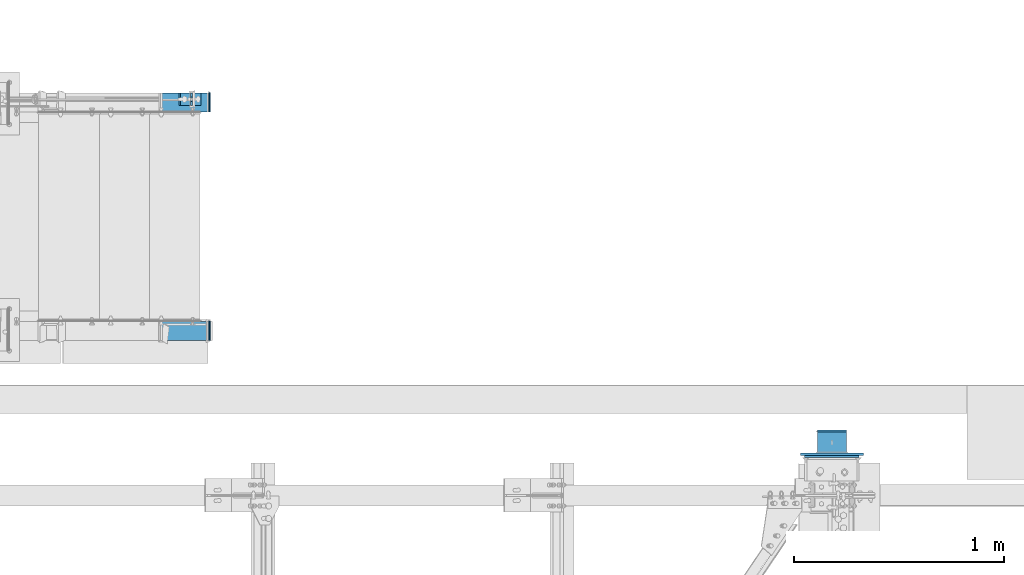
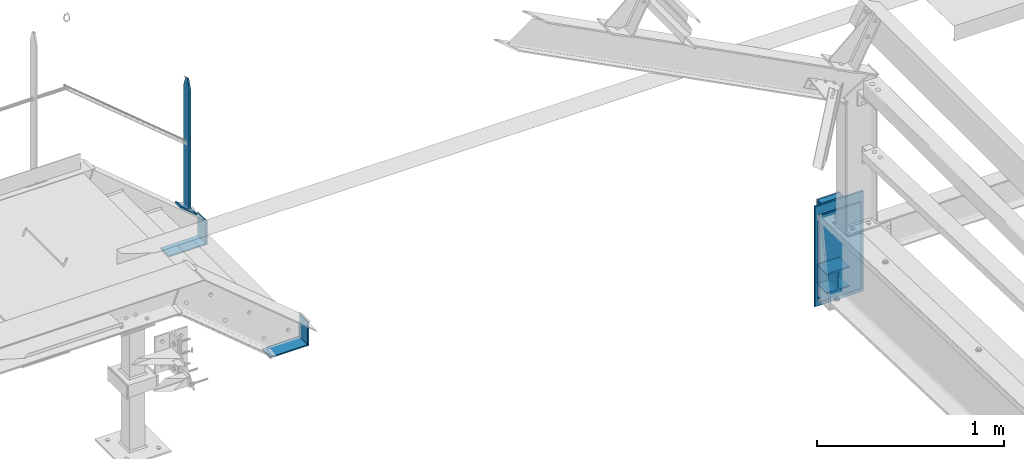
# One storey, part 99 of 496: 11 beams, 1 member, 5 elements without a shape of their own.
"""IFC2X3 building model written with IfcOpenShell, lengths in millimetres."""

from ifc_helpers import new_model, si_unit, frame, origin_with_axes, origin_2d_with_axis, place, context, subcontext, project, spatial, rectangle, i_section, extrude, clip, halfspace, material, type_object, element, aggregate, save


model = new_model("IFC2X3")

# Units and contexts
model_context = context("Model", 3, precision=1e-05, world=origin_with_axes())
body_context = subcontext(model_context, "Body", "Model", "MODEL_VIEW")
ifc_project = project(units=[si_unit("LENGTHUNIT", "METRE", prefix="MILLI"), si_unit("AREAUNIT", "SQUARE_METRE"), si_unit("VOLUMEUNIT", "CUBIC_METRE"), si_unit("MASSUNIT", "GRAM", prefix="KILO"), si_unit("TIMEUNIT", "SECOND"), si_unit("PLANEANGLEUNIT", "RADIAN"), si_unit("SOLIDANGLEUNIT", "STERADIAN"), si_unit("THERMODYNAMICTEMPERATUREUNIT", "DEGREE_CELSIUS"), si_unit("LUMINOUSINTENSITYUNIT", "LUMEN")], contexts=[model_context])

# Site, building, storey
site_placement = place(None, origin_with_axes())
site = spatial("IfcSite", under=ifc_project, at=site_placement, CompositionType="ELEMENT")
building_placement = place(site_placement, origin_with_axes())
building = spatial("IfcBuilding", under=site, at=building_placement, Name="Undefined", CompositionType="ELEMENT")
storey_placement = place(building_placement, origin_with_axes())
storey = spatial("IfcBuildingStorey", under=building, at=storey_placement, Name="Undefined", CompositionType="ELEMENT", Elevation=0.0)

# Assembly, beam
assembly_1_placement = place(storey_placement, origin_with_axes())
assembly_1 = element("IfcElementAssembly", 1, at=assembly_1_placement, inside=storey, Name="MAIN COURANTE", AssemblyPlace="NOTDEFINED", PredefinedType="NOTDEFINED")
ifc_material_1 = material(Name="Undefined/S235-E24")
beam_type_1 = type_object("IfcBeamType", PredefinedType="NOTDEFINED")
beam_1_placement = place(assembly_1_placement, frame((25825.0061849193, 17089.9938659712, 8458.13573617826), z_axis=(0.0, -1.0, 0.0), x_axis=(0.0, 0.0, -1.0)))
beam_1 = element("IfcBeam", 2, at=beam_1_placement, type_object=beam_type_1, material=ifc_material_1, Name="MONTANT", context=body_context, shape_type="Clipping", body=[
    clip(clip(clip(clip(extrude(rectangle(XDim=10.0, YDim=60.0, at=origin_2d_with_axis()), frame((860.207207578186, 0.0, 0.0), z_axis=(-1.0, 0.0, 0.0), x_axis=(0.0, -1.0, 0.0)), (0.0, 0.0, 1.0), 868.62), halfspace(frame((-120.0, 5.0, -30.0), z_axis=(-0.316227766016838, 0.0, 0.948683298050514), x_axis=(0.948683298050514, 0.0, 0.316227766016838)), False)), halfspace(frame((60.0, 5.0, -30.0), z_axis=(-0.316227766016838, 0.0, -0.948683298050514), x_axis=(-0.948683298050514, 0.0, 0.316227766016838)), False)), halfspace(frame((858.302366962016, 7.81419051646299, 0.0), z_axis=(0.768221279597369, -0.640184399664488, 0.0), x_axis=(0.0, 0.0, -1.0)), False)), halfspace(frame((5.77492361636723, 6.92990936078422, 0.0), z_axis=(0.768221279597369, -0.640184399664488, 0.0), x_axis=(0.0, 0.0, -1.0)), True)),
])

assembly_2_placement = place(storey_placement, origin_with_axes())
assembly_2 = element("IfcElementAssembly", 3, at=assembly_2_placement, inside=storey, AssemblyPlace="NOTDEFINED", PredefinedType="NOTDEFINED")
beam_type_2 = type_object("IfcBeamType", PredefinedType="NOTDEFINED")
beam_2_placement = place(assembly_2_placement, frame((28880.000000027, 15396.0000000013, 7624.99732627141), z_axis=(-1.0, 0.0, 0.0), x_axis=(0.0, 0.0, -1.0)))
beam_2 = element("IfcBeam", 4, at=beam_2_placement, type_object=beam_type_2, material=ifc_material_1, context=body_context, shape_type="SweptSolid", body=[
    extrude(rectangle(XDim=12.0, YDim=300.0, at=origin_2d_with_axis()), frame((654.999999999754, 0.0, 0.0), z_axis=(-1.0, 0.0, 0.0), x_axis=(0.0, -1.0, 0.0)), (0.0, 0.0, 1.0), 655.0),
])

# Member
member_type = type_object("IfcMemberType", PredefinedType="NOTDEFINED")
member_placement = place(assembly_1_placement, frame((25867.8985396968, 17089.9938659712, 7564.09302426877), z_axis=(0.0, 1.0, 0.0), x_axis=(-0.768221279597376, 0.0, 0.640184399664479)))
member = element("IfcMember", 5, at=member_placement, type_object=member_type, material=ifc_material_1, context=body_context, shape_type="SweptSolid", body=[
    extrude(rectangle(XDim=10.0, YDim=60.0, at=origin_2d_with_axis()), frame((130.0, 0.0, 0.0), z_axis=(-1.0, 0.0, 0.0), x_axis=(0.0, -1.0, 0.0)), (0.0, 0.0, 1.0), 130.0),
])

aggregate(assembly_1, [member, beam_1])

# Assembly, beams
assembly_3_placement = place(storey_placement, origin_with_axes())
assembly_3 = element("IfcElementAssembly", 6, at=assembly_3_placement, inside=storey, AssemblyPlace="NOTDEFINED", PredefinedType="NOTDEFINED")
beam_type_3 = type_object("IfcBeamType", PredefinedType="NOTDEFINED")
beam_3_placement = place(assembly_3_placement, frame((25914.9999902344, 15984.9998774357, 7373.99994075732), z_axis=(0.0, -1.0, 0.0), x_axis=(-1.0, 0.0, 0.0)))
beam_3 = element("IfcBeam", 7, at=beam_3_placement, type_object=beam_type_3, material=ifc_material_1, Name="PLAT", context=body_context, shape_type="SweptSolid", body=[
    extrude(rectangle(XDim=8.0, YDim=90.0, at=origin_2d_with_axis()), frame((237.732983147944, 0.0, 0.0), z_axis=(-1.0, 0.0, 0.0), x_axis=(0.0, -1.0, 0.0)), (0.0, 0.0, 1.0), 237.73),
])
beam_4_placement = place(assembly_3_placement, frame((25910.9999902344, 15984.9998774357, 7524.9999407576), z_axis=(0.0, -1.0, 0.0), x_axis=(0.0, 0.0, -1.0)))
beam_4 = element("IfcBeam", 8, at=beam_4_placement, type_object=beam_type_3, material=ifc_material_1, Name="PLAT", context=body_context, shape_type="SweptSolid", body=[
    extrude(rectangle(XDim=8.0, YDim=90.0, at=origin_2d_with_axis()), frame((147.00000000028, 0.0, 0.0), z_axis=(-1.0, 0.0, 0.0), x_axis=(0.0, -1.0, 0.0)), (0.0, 0.0, 1.0), 147.0),
])
aggregate(assembly_3, [beam_3, beam_4])

assembly_4_placement = place(storey_placement, origin_with_axes())
assembly_4 = element("IfcElementAssembly", 9, at=assembly_4_placement, inside=storey, AssemblyPlace="NOTDEFINED", PredefinedType="NOTDEFINED")
beam_5_placement = place(assembly_4_placement, frame((25914.9999902344, 17074.9998774393, 7373.99994075732), z_axis=(0.0, 1.0, 0.0), x_axis=(-1.0, 0.0, 0.0)))
beam_5 = element("IfcBeam", 10, at=beam_5_placement, type_object=beam_type_3, material=ifc_material_1, Name="PLAT", context=body_context, shape_type="SweptSolid", body=[
    extrude(rectangle(XDim=8.0, YDim=90.0, at=origin_2d_with_axis()), frame((237.732983147944, 0.0, 0.0), z_axis=(-1.0, 0.0, 0.0), x_axis=(0.0, -1.0, 0.0)), (0.0, 0.0, 1.0), 237.73),
])
beam_6_placement = place(assembly_4_placement, frame((25910.9999902344, 17074.9998774393, 7524.99994075624), z_axis=(0.0, 1.0, 0.0), x_axis=(0.0, 0.0, -1.0)))
beam_6 = element("IfcBeam", 11, at=beam_6_placement, type_object=beam_type_3, material=ifc_material_1, Name="PLAT", context=body_context, shape_type="SweptSolid", body=[
    extrude(rectangle(XDim=8.0, YDim=90.0, at=origin_2d_with_axis()), frame((147.00000000028, 0.0, 0.0), z_axis=(-1.0, 0.0, 0.0), x_axis=(0.0, -1.0, 0.0)), (0.0, 0.0, 1.0), 147.0),
])
aggregate(assembly_4, [beam_5, beam_6])

# Beam
beam_type_4 = type_object("IfcBeamType", PredefinedType="NOTDEFINED")
beam_7_placement = place(assembly_2_placement, frame((28880.0000000283, 15507.0000000015, 7151.49732627159), z_axis=(-1.0, 0.0, 0.0), x_axis=(0.0, 0.0, -1.0)))
beam_7 = element("IfcBeam", 12, at=beam_7_placement, type_object=beam_type_4, material=ifc_material_1, Name="PLAT", context=body_context, shape_type="SweptSolid", body=[
    extrude(rectangle(XDim=10.0, YDim=140.0, at=origin_2d_with_axis()), frame((132.999999999945, 0.0, 0.0), z_axis=(-1.0, 0.0, 0.0), x_axis=(0.0, -1.0, 0.0)), (0.0, 0.0, 1.0), 133.0),
])

beam_8_placement = place(assembly_2_placement, frame((28880.0000000282, 15507.0000000014, 7576.49732627143), z_axis=(-1.0, 0.0, 0.0), x_axis=(0.0, 0.0, -1.0)))
beam_8 = element("IfcBeam", 13, at=beam_8_placement, type_object=beam_type_4, material=ifc_material_1, Name="PLAT", context=body_context, shape_type="SweptSolid", body=[
    extrude(rectangle(XDim=10.0, YDim=140.0, at=origin_2d_with_axis()), frame((132.999999999945, 0.0, 0.0), z_axis=(-1.0, 0.0, 0.0), x_axis=(0.0, -1.0, 0.0)), (0.0, 0.0, 1.0), 133.0),
])

ifc_material_2 = material(Name="Undefined/S275-E28")
beam_type_5 = type_object("IfcBeamType", Name="HEA140", PredefinedType="NOTDEFINED")
beam_9_placement = place(assembly_2_placement, frame((28880.0000000269, 15402.0000000013, 7084.99732627159), z_axis=(0.0, 0.0, 1.0), x_axis=(0.0, 1.0, 0.0)))
beam_9 = element("IfcBeam", 14, at=beam_9_placement, type_object=beam_type_5, material=ifc_material_2, ObjectType="HEA140", context=body_context, shape_type="SweptSolid", body=[
    extrude(i_section(OverallWidth=140.0, OverallDepth=133.0, WebThickness=5.5, FlangeThickness=8.5, FilletRadius=12.0, at=origin_2d_with_axis()), frame((100.000000000021, 5.72981662116945e-11, -4.09272615797818e-12), z_axis=(-1.0, 0.0, 0.0), x_axis=(0.0, -1.0, 0.0)), (0.0, 0.0, 1.0), 100.0),
])

beam_10_placement = place(assembly_2_placement, frame((28880.000000027, 15402.0000000012, 7509.99732627145), z_axis=(0.0, 0.0, 1.0), x_axis=(0.0, 1.0, 0.0)))
beam_10 = element("IfcBeam", 15, at=beam_10_placement, type_object=beam_type_5, material=ifc_material_2, ObjectType="HEA140", context=body_context, shape_type="SweptSolid", body=[
    extrude(i_section(OverallWidth=140.0, OverallDepth=133.0, WebThickness=5.5, FlangeThickness=8.5, FilletRadius=12.0, at=origin_2d_with_axis()), frame((100.000000000021, 5.72981662116945e-11, -4.09272615797818e-12), z_axis=(-1.0, 0.0, 0.0), x_axis=(0.0, -1.0, 0.0)), (0.0, 0.0, 1.0), 100.0),
])

aggregate(assembly_2, [beam_7, beam_9, beam_8, beam_10, beam_2])

# Assembly, beam
assembly_5_placement = place(storey_placement, origin_with_axes())
assembly_5 = element("IfcElementAssembly", 16, at=assembly_5_placement, inside=storey, AssemblyPlace="NOTDEFINED", PredefinedType="NOTDEFINED")
beam_type_6 = type_object("IfcBeamType", PredefinedType="NOTDEFINED")
beam_11_placement = place(assembly_5_placement, frame((28880.0000000257, 15385.0000000017, 7564.99732627142), z_axis=(-1.0, 0.0, 0.0), x_axis=(0.0, 0.0, -1.0)))
beam_11 = element("IfcBeam", 17, at=beam_11_placement, type_object=beam_type_6, material=ifc_material_1, context=body_context, shape_type="SweptSolid", body=[
    extrude(rectangle(XDim=10.0, YDim=260.0, at=origin_2d_with_axis()), frame((564.999999999777, 0.0, 0.0), z_axis=(-1.0, 0.0, 0.0), x_axis=(0.0, -1.0, 0.0)), (0.0, 0.0, 1.0), 565.0),
])
aggregate(assembly_5, [beam_11])

save(model, "model.ifc")
